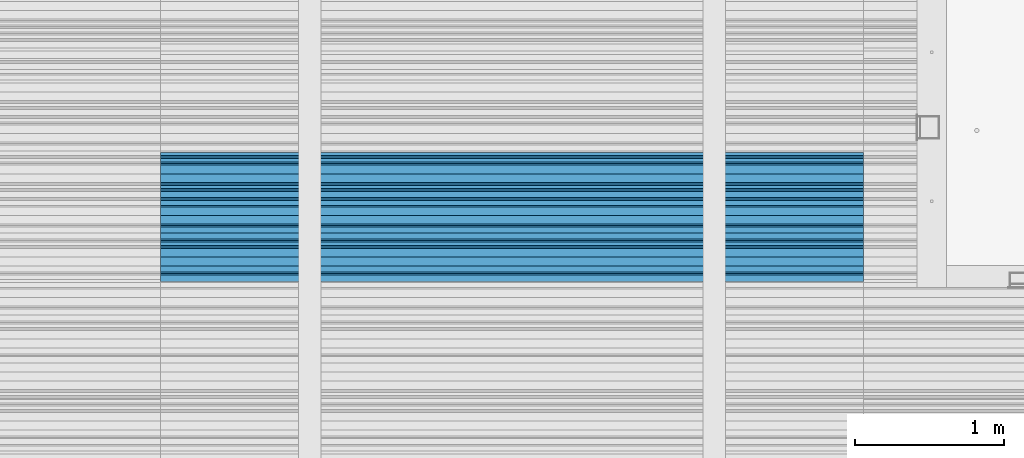
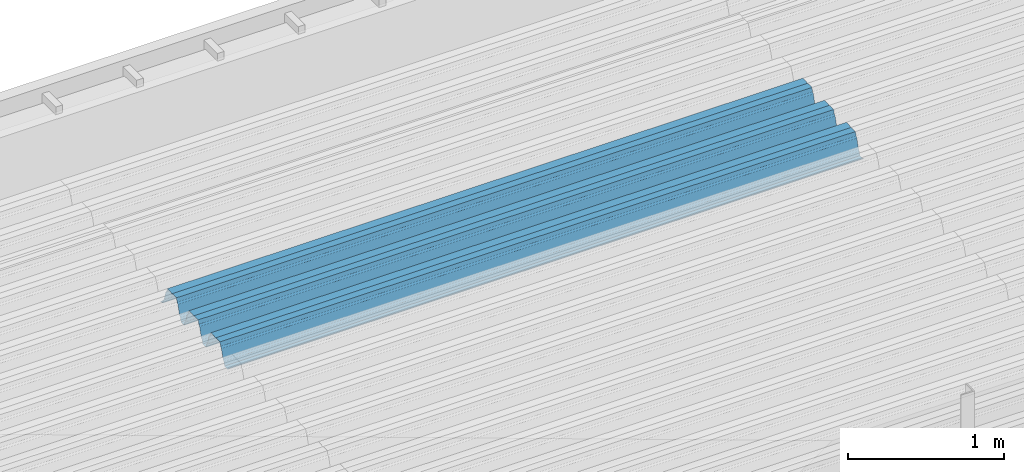
# One storey, part 33 of 153: 1 beam, 1 element without a shape of its own.
"""IFC2X3 building model written with IfcOpenShell, lengths in millimetres."""

from ifc_helpers import new_model, si_unit, frame, origin_with_axes, place, context, subcontext, project, spatial, faceted_brep, material, type_object, element, aggregate, save


model = new_model("IFC2X3")

# Units and contexts
model_context = context("Model", 3, precision=1e-05, world=origin_with_axes())
body_context = subcontext(model_context, "Body", "Model", "MODEL_VIEW")
ifc_project = project(units=[si_unit("LENGTHUNIT", "METRE", prefix="MILLI"), si_unit("AREAUNIT", "SQUARE_METRE"), si_unit("VOLUMEUNIT", "CUBIC_METRE"), si_unit("MASSUNIT", "GRAM", prefix="KILO"), si_unit("TIMEUNIT", "SECOND"), si_unit("PLANEANGLEUNIT", "RADIAN"), si_unit("SOLIDANGLEUNIT", "STERADIAN"), si_unit("THERMODYNAMICTEMPERATUREUNIT", "DEGREE_CELSIUS"), si_unit("LUMINOUSINTENSITYUNIT", "LUMEN")], contexts=[model_context])

# Site, building, storey
site_placement = place(None, origin_with_axes())
site = spatial("IfcSite", under=ifc_project, at=site_placement, CompositionType="ELEMENT")
building_placement = place(site_placement, origin_with_axes())
building = spatial("IfcBuilding", under=site, at=building_placement, CompositionType="ELEMENT")
storey_placement = place(building_placement, origin_with_axes())
storey = spatial("IfcBuildingStorey", under=building, at=storey_placement, Name="8", CompositionType="ELEMENT", Elevation=0.0)

# Assembly, beam
assembly_placement = place(storey_placement, origin_with_axes())
assembly = element("IfcElementAssembly", 1, at=assembly_placement, inside=storey, Name="Steel Assembly", AssemblyPlace="NOTDEFINED", PredefinedType="RIGID_FRAME")
ifc_material = material(Name="STEEL/S355J2")
beam_type = type_object("IfcBeamType", Name="W", PredefinedType="NOTDEFINED")
beam_placement = place(assembly_placement, frame((17251.9999999917, 18704.9497094901, 105791.39725794), z_axis=(0.0, -0.0124990270013869, 0.999921884110963), x_axis=(-1.0, 3.00000001838171e-08, 0.0)))
beam = element("IfcBeam", 2, at=beam_placement, type_object=beam_type, material=ifc_material, ObjectType="W", context=body_context, shape_type="Brep", body=[
    faceted_brep([(0.0, -412.839996337891, -77.0100021362159), (0.0, -409.160003662109, -77.0100021362014), (4717.0, -409.160003662109, -77.0100021362159), (4717.0, -412.839996337891, -77.0100021362159), (0.0, -408.070007324222, -73.4800033569045), (4717.0, -408.070007324222, -73.480003356919), (0.0, -400.339996337894, -48.0600013732619), (4717.0, -400.339996337894, -48.0600013732765), (0.0, -399.459991455082, -46.5600013732619), (4717.0, -399.459991455078, -46.5600013732765), (0.0, -390.329986572269, -36.5499992370314), (4717.0, -390.329986572266, -36.549999237046), (0.0, -389.19000244141, -34.6300010680861), (4717.0, -389.190002441403, -34.6300010681007), (0.0, -367.820007324222, 35.3400001526024), (4717.0, -367.820007324219, 35.3400001525879), (0.0, -366.989990234379, 36.8499984741502), (4717.0, -366.989990234375, 36.8499984741356), (0.0, -357.809997558597, 46.8600006103807), (4717.0, -357.809997558594, 46.8600006103661), (0.0, -356.720001220707, 48.7700004577782), (4717.0, -356.720001220703, 48.7700004577782), (0.0, -349.309997558594, 73.1500015258935), (4717.0, -349.309997558594, 73.1500015258935), (0.0, -347.850006103516, 75.2300033569481), (4717.0, -347.850006103516, 75.2300033569481), (0.0, -345.470001220707, 76.010002136245), (4717.0, -345.470001220703, 76.0100021362305), (0.0, -305.480010986332, 76.010002136245), (4717.0, -305.480010986324, 76.0100021362305), (0.0, -304.279998779301, 75.8000030517578), (4717.0, -304.279998779301, 75.8000030517724), (0.0, -291.679992675785, 71.6999969482567), (4717.0, -291.679992675785, 71.6999969482567), (0.0, -290.179992675789, 71.2300033569481), (4717.0, -290.179992675781, 71.2300033569481), (0.0, -288.720001220707, 71.6999969482567), (4717.0, -288.720001220703, 71.6999969482422), (0.0, -276.119995117191, 75.8000030517869), (4717.0, -276.119995117188, 75.8000030517724), (0.0, -274.929992675785, 76.010002136245), (4717.0, -274.929992675785, 76.010002136245), (0.0, -234.94000244141, 76.010002136245), (4717.0, -234.94000244141, 76.010002136245), (0.0, -232.550003051758, 75.2300033569627), (4717.0, -232.550003051758, 75.2300033569481), (0.0, -231.100006103519, 73.1500015258935), (4717.0, -231.100006103516, 73.1500015258789), (0.0, -223.679992675785, 48.7700004577782), (4717.0, -223.679992675781, 48.7700004577782), (0.0, -222.589996337894, 46.8600006103661), (4717.0, -222.589996337891, 46.8600006103516), (0.0, -213.410003662113, 36.8499984741502), (4717.0, -213.410003662109, 36.8499984741356), (0.0, -212.529998779301, 35.3400001526024), (4717.0, -212.529998779297, 35.3400001526024), (0.0, -191.160003662109, -34.6300010681007), (4717.0, -191.160003662109, -34.6300010681007), (0.0, -190.070007324222, -36.5499992370605), (4717.0, -190.070007324215, -36.549999237046), (0.0, -180.940002441406, -46.560001373291), (4717.0, -180.940002441406, -46.5600013732765), (0.0, -180.059997558597, -48.0600013732619), (4717.0, -180.059997558594, -48.0600013732765), (0.0, -172.330001831055, -73.480003356919), (4717.0, -172.330001831055, -73.480003356919), (0.0, -171.240005493168, -77.0100021362159), (4717.0, -171.240005493164, -77.0100021362159), (0.0, -129.330001831062, -77.0100021362014), (4717.0, -129.330001831055, -77.0100021362159), (0.0, -128.300003051761, -73.480003356919), (4717.0, -128.300003051758, -73.4800033569336), (0.0, -120.51999664307, -48.0600013732765), (4717.0, -120.519996643063, -48.0600013732765), (0.0, -119.629997253418, -46.5600013732765), (4717.0, -119.629997253418, -46.5600013732765), (0.0, -110.500000000004, -36.5499992370314), (4717.0, -110.5, -36.549999237046), (0.0, -109.419998168949, -34.6300010680861), (4717.0, -109.419998168945, -34.6300010681007), (0.0, -88.0500030517615, 35.3400001526024), (4717.0, -88.0500030517578, 35.3400001526024), (0.0, -87.160003662113, 36.8499984741356), (4717.0, -87.160003662113, 36.8499984741356), (0.0, -78.0400009155273, 46.8600006103807), (4717.0, -78.0400009155273, 46.8600006103661), (0.0, -76.8899993896557, 48.7700004577782), (4717.0, -76.8899993896521, 48.7700004577782), (0.0, -69.4800033569336, 73.1500015258935), (4717.0, -69.4800033569336, 73.1500015258935), (0.0, -68.0299987793042, 75.2300033569336), (4717.0, -68.0299987792969, 75.2300033569481), (0.0, -65.6399993896521, 76.010002136245), (4717.0, -65.6399993896484, 76.010002136245), (0.0, -25.6499996185375, 76.0100021362596), (4717.0, -25.6499996185303, 76.010002136245), (0.0, -24.5100002288891, 75.8000030517724), (4717.0, -24.5100002288818, 75.8000030517724), (0.0, -11.8500003814697, 71.6999969482567), (4717.0, -11.8500003814661, 71.6999969482567), (0.0, -10.3999996185339, 71.2300033569481), (4717.0, -10.3999996185303, 71.2300033569336), (0.0, -8.89999961853391, 71.6999969482567), (4717.0, -8.89999961853391, 71.6999969482567), (0.0, 3.71000003814333, 75.8000030517724), (4717.0, 3.71000003814697, 75.8000030517869), (0.0, 4.90000009536379, 76.0100021362596), (4717.0, 4.90000009536379, 76.010002136245), (0.0, 44.8899993896484, 76.010002136245), (4717.0, 44.8899993896484, 76.010002136245), (0.0, 47.2799987792932, 75.2300033569481), (4717.0, 47.2799987792969, 75.2300033569481), (0.0, 48.6800003051721, 73.1500015258935), (4717.0, 48.6800003051758, 73.1500015258789), (0.0, 56.1500015258753, 48.7700004577782), (4717.0, 56.1500015258789, 48.7700004577782), (0.0, 57.2400016784632, 46.8600006103807), (4717.0, 57.2400016784632, 46.8600006103661), (0.0, 66.3700027465784, 36.8499984741211), (4717.0, 66.3700027465857, 36.8499984741356), (0.0, 67.2499999999964, 35.3400001526024), (4717.0, 67.2500000000036, 35.3400001526024), (0.0, 88.6200027465748, -34.6300010681007), (4717.0, 88.620002746582, -34.6300010681152), (0.0, 89.709999084469, -36.549999237046), (4717.0, 89.7099990844727, -36.5499992370605), (0.0, 98.8899993896412, -46.5600013732765), (4717.0, 98.8899993896484, -46.5600013732765), (0.0, 99.7699966430628, -48.0600013732765), (4717.0, 99.7699966430664, -48.060001373291), (0.0, 107.499999999996, -73.4800033569336), (4717.0, 107.5, -73.480003356919), (0.0, 108.589996337887, -77.0100021362014), (4717.0, 108.589996337894, -77.0100021362159), (0.0, 112.269996643063, -77.0100021362159), (4717.0, 112.269996643066, -77.0100021362159), (0.0, 146.759994506836, -77.0100021362159), (4717.0, 146.759994506836, -77.0100021362159), (0.0, 150.440002441403, -77.0100021362159), (4717.0, 150.440002441403, -77.0100021362305), (0.0, 151.529998779297, -73.480003356919), (4717.0, 151.529998779297, -73.4800033569336), (0.0, 159.30999755859, -48.0600013732765), (4717.0, 159.309997558594, -48.0600013732765), (0.0, 160.190002441406, -46.5600013732619), (4717.0, 160.190002441406, -46.5600013732765), (0.0, 169.320007324215, -36.549999237046), (4717.0, 169.320007324222, -36.5499992370605), (0.0, 170.410003662106, -34.6300010680861), (4717.0, 170.410003662109, -34.6300010681007), (0.0, 191.779998779293, 35.3400001526024), (4717.0, 191.779998779293, 35.3400001526024), (0.0, 192.660003662109, 36.8499984741502), (4717.0, 192.660003662109, 36.8499984741356), (0.0, 201.789993286129, 46.8600006103661), (4717.0, 201.789993286133, 46.8600006103661), (0.0, 202.880004882809, 48.7700004577637), (4717.0, 202.880004882813, 48.7700004577782), (0.0, 210.350006103512, 73.150001525908), (4717.0, 210.350006103516, 73.1500015258935), (0.0, 211.800003051754, 75.2300033569481), (4717.0, 211.800003051758, 75.2300033569336), (0.0, 214.190002441406, 76.010002136245), (4717.0, 214.19000244141, 76.010002136245), (0.0, 254.179992675778, 76.010002136245), (4717.0, 254.179992675778, 76.010002136245), (0.0, 255.320007324215, 75.8000030517869), (4717.0, 255.320007324222, 75.8000030517724), (0.0, 267.980010986324, 71.6999969482713), (4717.0, 267.980010986328, 71.6999969482567), (0.0, 269.429992675778, 71.2300033569481), (4717.0, 269.429992675781, 71.2300033569481), (0.0, 270.880004882809, 71.6999969482567), (4717.0, 270.880004882813, 71.6999969482567), (0.0, 283.540008544918, 75.8000030517869), (4717.0, 283.540008544918, 75.8000030517724), (0.0, 284.679992675778, 76.010002136245), (4717.0, 284.679992675778, 76.010002136245), (0.0, 324.670013427731, 76.010002136245), (4717.0, 324.670013427738, 76.010002136245), (0.0, 327.049987792969, 75.2300033569627), (4717.0, 327.049987792969, 75.2300033569481), (0.0, 328.510009765625, 73.1500015258789), (4717.0, 328.510009765625, 73.1500015258935), (0.0, 335.980010986324, 48.7700004577782), (4717.0, 335.980010986328, 48.7700004577782), (0.0, 337.05999755859, 46.8600006103661), (4717.0, 337.059997558594, 46.8600006103516), (0.0, 346.190002441399, 36.8499984741356), (4717.0, 346.190002441406, 36.8499984741211), (0.0, 347.079986572266, 35.3400001526024), (4717.0, 347.079986572266, 35.3400001526024), (0.0, 368.450012207028, -34.6300010680861), (4717.0, 368.450012207035, -34.6300010681007), (0.0, 369.529998779293, -36.5499992370314), (4717.0, 369.529998779297, -36.549999237046), (0.0, 378.660003662106, -46.5600013732619), (4717.0, 378.660003662106, -46.5600013732765), (0.0, 379.540008544918, -48.0600013732619), (4717.0, 379.540008544922, -48.0600013732765), (0.0, 387.329986572262, -73.480003356919), (4717.0, 387.329986572266, -73.4800033569045), (0.0, 388.410003662109, -77.0100021362159), (4717.0, 388.410003662109, -77.0100021362159), (0.0, 392.100006103512, -77.0100021362159), (4717.0, 392.100006103519, -77.0100021362159), (0.0, 426.589996337887, -77.0100021362159), (4717.0, 426.589996337891, -77.0100021362159), (0.0, 430.269989013668, -77.0100021362159), (4717.0, 430.269989013672, -77.0100021362305), (0.0, 431.359985351559, -73.4800033569045), (4717.0, 431.359985351563, -73.480003356919), (0.0, 433.179992675778, -67.5699996948097), (4717.0, 433.179992675781, -67.5699996948097), (0.0, 432.220001220699, -67.2699966430373), (4717.0, 432.220001220703, -67.2699966430519), (0.0, 430.410003662106, -73.1800003051612), (4717.0, 430.410003662106, -73.1800003051758), (0.0, 429.529998779293, -76.0100021362159), (4717.0, 429.529998779293, -76.0100021362159), (0.0, 426.589996337891, -76.0100021362159), (4717.0, 426.589996337891, -76.0100021362159), (0.0, 392.100006103512, -76.0100021362159), (4717.0, 392.100006103516, -76.0100021362159), (0.0, 389.149993896481, -76.0100021362014), (4717.0, 389.149993896484, -76.0100021362159), (0.0, 388.279998779293, -73.1800003051467), (4717.0, 388.279998779301, -73.1800003051612), (0.0, 380.470001220699, -47.659999847383), (4717.0, 380.470001220703, -47.6599998473976), (0.0, 379.470001220699, -45.9599990844436), (4717.0, 379.470001220703, -45.9599990844581), (0.0, 370.350006103512, -35.9599990844581), (4717.0, 370.350006103519, -35.9599990844581), (0.0, 369.369995117184, -34.2299995422218), (4717.0, 369.369995117184, -34.2299995422218), (0.0, 347.999999999996, 35.7500000000146), (4717.0, 348.0, 35.7500000000146), (0.0, 346.999999999996, 37.4399986267235), (4717.0, 347.000000000004, 37.4399986267235), (0.0, 337.880004882809, 47.450000762954), (4717.0, 337.880004882809, 47.4500007629395), (0.0, 336.899993896481, 49.1699981689453), (4717.0, 336.899993896484, 49.1699981689599), (0.0, 329.420013427731, 73.5999984741356), (4717.0, 329.420013427734, 73.5999984741356), (0.0, 327.679992675781, 76.0699996948533), (4717.0, 327.679992675781, 76.0699996948388), (0.0, 324.829986572262, 77.010002136245), (4717.0, 324.829986572266, 77.0100021362305), (0.0, 284.589996337887, 77.010002136245), (4717.0, 284.589996337891, 77.010002136245), (0.0, 283.290008544922, 76.769996643081), (4717.0, 283.290008544922, 76.769996643081), (0.0, 270.570007324215, 72.6500015258935), (4717.0, 270.570007324219, 72.6500015258935), (0.0, 269.429992675781, 72.2799987793114), (4717.0, 269.429992675781, 72.2799987793114), (0.0, 268.279998779293, 72.650001525908), (4717.0, 268.279998779297, 72.6500015258935), (0.0, 255.570007324219, 76.769996643081), (4717.0, 255.570007324219, 76.769996643081), (0.0, 254.270004272461, 77.0100021362596), (4717.0, 254.270004272461, 77.010002136245), (0.0, 214.029998779293, 77.0100021362596), (4717.0, 214.029998779297, 77.010002136245), (0.0, 211.179992675781, 76.0699996948388), (4717.0, 211.179992675781, 76.0699996948533), (0.0, 209.440002441403, 73.5999984741356), (4717.0, 209.44000244141, 73.5999984741211), (0.0, 201.960006713864, 49.1699981689599), (4717.0, 201.960006713867, 49.1699981689453), (0.0, 200.979995727532, 47.450000762954), (4717.0, 200.979995727539, 47.4500007629395), (0.0, 191.850006103508, 37.4399986267235), (4717.0, 191.850006103516, 37.439998626709), (0.0, 190.860000610352, 35.7500000000146), (4717.0, 190.860000610352, 35.75), (0.0, 169.49000549316, -34.2299995422218), (4717.0, 169.49000549316, -34.2299995422363), (0.0, 168.509994506832, -35.9599990844581), (4717.0, 168.509994506836, -35.9599990844581), (0.0, 159.380004882805, -45.9599990844436), (4717.0, 159.380004882813, -45.9599990844581), (0.0, 158.389999389645, -47.6599998473976), (4717.0, 158.389999389645, -47.6599998474121), (0.0, 150.580001831051, -73.1800003051612), (4717.0, 150.580001831058, -73.1800003051758), (0.0, 149.710006713864, -76.0100021362159), (4717.0, 149.710006713867, -76.0100021362159), (0.0, 146.759994506836, -76.0100021362159), (4717.0, 146.759994506836, -76.0100021362159), (0.0, 112.269996643063, -76.0100021362159), (4717.0, 112.269996643063, -76.0100021362159), (0.0, 109.319999694821, -76.0100021362159), (4717.0, 109.319999694821, -76.0100021362159), (0.0, 108.449996948239, -73.1900024413917), (4717.0, 108.449996948242, -73.1900024414063), (0.0, 100.690002441406, -47.659999847383), (4717.0, 100.69000244141, -47.6599998473976), (0.0, 99.6999969482386, -45.9599990844581), (4717.0, 99.6999969482422, -45.9599990844581), (0.0, 90.5199966430664, -35.9599990844581), (4717.0, 90.5199966430664, -35.9599990844727), (0.0, 89.5400009155273, -34.2299995422218), (4717.0, 89.5400009155273, -34.2299995422218), (0.0, 68.1699981689417, 35.7500000000146), (4717.0, 68.1699981689453, 35.7500000000146), (0.0, 67.1699981689417, 37.4399986267235), (4717.0, 67.1699981689453, 37.4399986267235), (0.0, 58.0499992370569, 47.4500007629686), (4717.0, 58.0499992370605, 47.450000762954), (0.0, 57.0699996948206, 49.1699981689599), (4717.0, 57.0699996948279, 49.1699981689453), (0.0, 49.5900001525843, 73.5899963379052), (4717.0, 49.5900001525879, 73.5899963378906), (0.0, 47.9099998474085, 76.0699996948388), (4717.0, 47.9099998474121, 76.0699996948242), (0.0, 45.0499992370569, 77.010002136245), (4717.0, 45.0499992370605, 77.010002136245), (0.0, 4.82000017165774, 77.010002136245), (4717.0, 4.82000017166138, 77.010002136245), (0.0, 3.47000002860659, 76.7699966430955), (4717.0, 3.47000002860659, 76.769996643081), (0.0, -9.19999980926514, 72.6500015258935), (4717.0, -9.19999980926514, 72.6500015258789), (0.0, -10.3900003433264, 72.2799987792969), (4717.0, -10.3900003433228, 72.2799987793114), (0.0, -11.5399999618567, 72.6500015258935), (4717.0, -11.5399999618494, 72.6500015258935), (0.0, -24.2600002288855, 76.769996643081), (4717.0, -24.2600002288818, 76.769996643081), (0.0, -25.559999465946, 77.0100021362596), (4717.0, -25.5599994659424, 77.010002136245), (0.0, -65.8000030517615, 77.0100021362596), (4717.0, -65.8000030517578, 77.010002136245), (0.0, -68.6500015258862, 76.0699996948533), (4717.0, -68.6500015258825, 76.0699996948388), (0.0, -70.3899993896521, 73.5999984741356), (4717.0, -70.3899993896484, 73.5999984741211), (0.0, -77.8199996948242, 49.1800003051903), (4717.0, -77.8199996948242, 49.1800003051903), (0.0, -78.8399963378943, 47.450000762954), (4717.0, -78.8399963378906, 47.4500007629395), (0.0, -87.9700012207031, 37.4399986267235), (4717.0, -87.9700012207031, 37.4399986267235), (0.0, -88.9700012207068, 35.7500000000146), (4717.0, -88.9700012207031, 35.75), (0.0, -110.339996337894, -34.2299995422218), (4717.0, -110.339996337887, -34.2299995422218), (0.0, -111.319999694828, -35.9599990844581), (4717.0, -111.319999694824, -35.9599990844581), (0.0, -120.440002441406, -45.9599990844436), (4717.0, -120.440002441406, -45.9599990844581), (0.0, -121.44000244141, -47.6599998473976), (4717.0, -121.440002441403, -47.6599998473976), (0.0, -129.250000000004, -73.1900024413771), (4717.0, -129.25, -73.1900024413917), (0.0, -130.080001831062, -76.0100021362159), (4717.0, -130.080001831055, -76.0100021362159), (0.0, -170.5, -76.0100021362014), (4717.0, -170.5, -76.0100021362159), (0.0, -171.380004882816, -73.1900024413917), (4717.0, -171.380004882813, -73.1900024414063), (0.0, -179.139999389652, -47.6599998473976), (4717.0, -179.139999389648, -47.6599998473976), (0.0, -180.130004882816, -45.9599990844581), (4717.0, -180.130004882813, -45.9599990844581), (0.0, -189.259994506836, -35.9599990844581), (4717.0, -189.259994506832, -35.9599990844581), (0.0, -190.240005493168, -34.2299995422218), (4717.0, -190.240005493164, -34.2299995422218), (0.0, -211.610000610355, 35.7500000000146), (4717.0, -211.610000610352, 35.7500000000146), (0.0, -212.600006103519, 37.4399986267381), (4717.0, -212.600006103519, 37.4399986267235), (0.0, -221.779998779301, 47.450000762954), (4717.0, -221.779998779293, 47.4500007629395), (0.0, -222.75999450684, 49.1699981689599), (4717.0, -222.759994506836, 49.1699981689599), (0.0, -230.190002441406, 73.5999984741356), (4717.0, -230.190002441406, 73.5999984741211), (0.0, -231.919998168945, 76.0699996948388), (4717.0, -231.919998168945, 76.0699996948388), (0.0, -234.779998779301, 77.010002136245), (4717.0, -234.779998779293, 77.010002136245), (0.0, -275.010009765629, 77.010002136245), (4717.0, -275.010009765625, 77.0100021362305), (0.0, -276.359985351563, 76.769996643081), (4717.0, -276.359985351563, 76.7699966430664), (0.0, -289.029998779297, 72.6500015258789), (4717.0, -289.029998779297, 72.6500015258935), (0.0, -290.179992675785, 72.2799987793114), (4717.0, -290.179992675785, 72.2799987793114), (0.0, -291.380004882816, 72.650001525908), (4717.0, -291.380004882813, 72.6500015258935), (0.0, -304.040008544926, 76.769996643081), (4717.0, -304.040008544918, 76.769996643081), (0.0, -305.390014648441, 77.010002136245), (4717.0, -305.390014648438, 77.010002136245), (0.0, -345.63000488282, 77.0100021362596), (4717.0, -345.630004882813, 77.010002136245), (0.0, -348.480010986332, 76.0699996948388), (4717.0, -348.480010986324, 76.0699996948388), (0.0, -350.220001220707, 73.5999984741356), (4717.0, -350.220001220703, 73.5999984741211), (0.0, -357.649993896492, 49.1699981689599), (4717.0, -357.649993896484, 49.1699981689744), (0.0, -358.63000488282, 47.450000762954), (4717.0, -358.630004882813, 47.450000762954), (0.0, -367.809997558594, 37.4300003051903), (4717.0, -367.809997558594, 37.4300003051903), (0.0, -368.750000000004, 35.7299995422654), (4717.0, -368.75, 35.7299995422509), (0.0, -390.109985351566, -34.2200012207031), (4717.0, -390.109985351563, -34.2200012206886), (0.0, -391.140014648441, -35.9500007629249), (4717.0, -391.140014648438, -35.9500007629103), (0.0, -400.269989013676, -45.9599990844436), (4717.0, -400.269989013672, -45.9599990844581), (0.0, -401.269989013672, -47.6599998473976), (4717.0, -401.269989013672, -47.6599998473976), (0.0, -409.029998779297, -73.1900024413917), (4717.0, -409.029998779297, -73.1900024413917), (0.0, -409.899993896488, -76.0100021362159), (4717.0, -409.899993896481, -76.0100021362305), (0.0, -412.839996337891, -76.0100021362159), (4717.0, -412.839996337891, -76.0100021362305), (0.0, -433.179992675785, -76.0100021362159), (4717.0, -433.179992675781, -76.0100021362159), (0.0, -433.179992675785, -77.0100021362159), (4717.0, -433.179992675785, -77.0100021362305)], [[[0, 1, 2, 3]], [[1, 4, 5, 2]], [[4, 6, 7, 5]], [[6, 8, 9, 7]], [[8, 10, 11, 9]], [[10, 12, 13, 11]], [[12, 14, 15, 13]], [[14, 16, 17, 15]], [[16, 18, 19, 17]], [[18, 20, 21, 19]], [[20, 22, 23, 21]], [[22, 24, 25, 23]], [[24, 26, 27, 25]], [[26, 28, 29, 27]], [[28, 30, 31, 29]], [[30, 32, 33, 31]], [[32, 34, 35, 33]], [[34, 36, 37, 35]], [[36, 38, 39, 37]], [[38, 40, 41, 39]], [[40, 42, 43, 41]], [[42, 44, 45, 43]], [[44, 46, 47, 45]], [[46, 48, 49, 47]], [[48, 50, 51, 49]], [[50, 52, 53, 51]], [[52, 54, 55, 53]], [[54, 56, 57, 55]], [[56, 58, 59, 57]], [[58, 60, 61, 59]], [[60, 62, 63, 61]], [[62, 64, 65, 63]], [[64, 66, 67, 65]], [[66, 68, 69, 67]], [[68, 70, 71, 69]], [[70, 72, 73, 71]], [[72, 74, 75, 73]], [[74, 76, 77, 75]], [[76, 78, 79, 77]], [[78, 80, 81, 79]], [[80, 82, 83, 81]], [[82, 84, 85, 83]], [[84, 86, 87, 85]], [[86, 88, 89, 87]], [[88, 90, 91, 89]], [[90, 92, 93, 91]], [[92, 94, 95, 93]], [[94, 96, 97, 95]], [[96, 98, 99, 97]], [[98, 100, 101, 99]], [[100, 102, 103, 101]], [[102, 104, 105, 103]], [[104, 106, 107, 105]], [[106, 108, 109, 107]], [[108, 110, 111, 109]], [[110, 112, 113, 111]], [[112, 114, 115, 113]], [[114, 116, 117, 115]], [[116, 118, 119, 117]], [[118, 120, 121, 119]], [[120, 122, 123, 121]], [[122, 124, 125, 123]], [[124, 126, 127, 125]], [[126, 128, 129, 127]], [[128, 130, 131, 129]], [[130, 132, 133, 131]], [[132, 134, 135, 133]], [[134, 136, 137, 135]], [[136, 138, 139, 137]], [[138, 140, 141, 139]], [[140, 142, 143, 141]], [[142, 144, 145, 143]], [[144, 146, 147, 145]], [[146, 148, 149, 147]], [[148, 150, 151, 149]], [[150, 152, 153, 151]], [[152, 154, 155, 153]], [[154, 156, 157, 155]], [[156, 158, 159, 157]], [[158, 160, 161, 159]], [[160, 162, 163, 161]], [[162, 164, 165, 163]], [[164, 166, 167, 165]], [[166, 168, 169, 167]], [[168, 170, 171, 169]], [[170, 172, 173, 171]], [[172, 174, 175, 173]], [[174, 176, 177, 175]], [[176, 178, 179, 177]], [[178, 180, 181, 179]], [[180, 182, 183, 181]], [[182, 184, 185, 183]], [[184, 186, 187, 185]], [[186, 188, 189, 187]], [[188, 190, 191, 189]], [[190, 192, 193, 191]], [[192, 194, 195, 193]], [[194, 196, 197, 195]], [[196, 198, 199, 197]], [[198, 200, 201, 199]], [[200, 202, 203, 201]], [[202, 204, 205, 203]], [[204, 206, 207, 205]], [[206, 208, 209, 207]], [[208, 210, 211, 209]], [[210, 212, 213, 211]], [[212, 214, 215, 213]], [[214, 216, 217, 215]], [[216, 218, 219, 217]], [[218, 220, 221, 219]], [[220, 222, 223, 221]], [[222, 224, 225, 223]], [[224, 226, 227, 225]], [[226, 228, 229, 227]], [[228, 230, 231, 229]], [[230, 232, 233, 231]], [[232, 234, 235, 233]], [[234, 236, 237, 235]], [[236, 238, 239, 237]], [[238, 240, 241, 239]], [[240, 242, 243, 241]], [[242, 244, 245, 243]], [[244, 246, 247, 245]], [[246, 248, 249, 247]], [[248, 250, 251, 249]], [[250, 252, 253, 251]], [[252, 254, 255, 253]], [[254, 256, 257, 255]], [[256, 258, 259, 257]], [[258, 260, 261, 259]], [[260, 262, 263, 261]], [[262, 264, 265, 263]], [[264, 266, 267, 265]], [[266, 268, 269, 267]], [[268, 270, 271, 269]], [[270, 272, 273, 271]], [[272, 274, 275, 273]], [[274, 276, 277, 275]], [[276, 278, 279, 277]], [[278, 280, 281, 279]], [[280, 282, 283, 281]], [[282, 284, 285, 283]], [[284, 286, 287, 285]], [[286, 288, 289, 287]], [[288, 290, 291, 289]], [[290, 292, 293, 291]], [[292, 294, 295, 293]], [[294, 296, 297, 295]], [[296, 298, 299, 297]], [[298, 300, 301, 299]], [[300, 302, 303, 301]], [[302, 304, 305, 303]], [[304, 306, 307, 305]], [[306, 308, 309, 307]], [[308, 310, 311, 309]], [[310, 312, 313, 311]], [[312, 314, 315, 313]], [[314, 316, 317, 315]], [[316, 318, 319, 317]], [[318, 320, 321, 319]], [[320, 322, 323, 321]], [[322, 324, 325, 323]], [[324, 326, 327, 325]], [[326, 328, 329, 327]], [[328, 330, 331, 329]], [[330, 332, 333, 331]], [[332, 334, 335, 333]], [[334, 336, 337, 335]], [[336, 338, 339, 337]], [[338, 340, 341, 339]], [[340, 342, 343, 341]], [[342, 344, 345, 343]], [[344, 346, 347, 345]], [[346, 348, 349, 347]], [[348, 350, 351, 349]], [[350, 352, 353, 351]], [[352, 354, 355, 353]], [[354, 356, 357, 355]], [[356, 358, 359, 357]], [[358, 360, 361, 359]], [[360, 362, 363, 361]], [[362, 364, 365, 363]], [[364, 366, 367, 365]], [[366, 368, 369, 367]], [[368, 370, 371, 369]], [[370, 372, 373, 371]], [[372, 374, 375, 373]], [[374, 376, 377, 375]], [[376, 378, 379, 377]], [[378, 380, 381, 379]], [[380, 382, 383, 381]], [[382, 384, 385, 383]], [[384, 386, 387, 385]], [[386, 388, 389, 387]], [[388, 390, 391, 389]], [[390, 392, 393, 391]], [[392, 394, 395, 393]], [[394, 396, 397, 395]], [[396, 398, 399, 397]], [[398, 400, 401, 399]], [[400, 402, 403, 401]], [[402, 404, 405, 403]], [[404, 406, 407, 405]], [[406, 408, 409, 407]], [[408, 410, 411, 409]], [[410, 412, 413, 411]], [[412, 414, 415, 413]], [[414, 416, 417, 415]], [[416, 418, 419, 417]], [[418, 420, 421, 419]], [[420, 422, 423, 421]], [[422, 424, 425, 423]], [[424, 426, 427, 425]], [[426, 428, 429, 427]], [[428, 430, 431, 429]], [[430, 0, 3, 431]], [[5, 7, 9, 11, 13, 15, 17, 19, 21, 23, 25, 27, 29, 31, 33, 35, 37, 39, 41, 43, 45, 47, 49, 51, 53, 55, 57, 59, 61, 63, 65, 67, 69, 71, 73, 75, 77, 79, 81, 83, 85, 87, 89, 91, 93, 95, 97, 99, 101, 103, 105, 107, 109, 111, 113, 115, 117, 119, 121, 123, 125, 127, 129, 131, 133, 135, 137, 139, 141, 143, 145, 147, 149, 151, 153, 155, 157, 159, 161, 163, 165, 167, 169, 171, 173, 175, 177, 179, 181, 183, 185, 187, 189, 191, 193, 195, 197, 199, 201, 203, 205, 207, 209, 211, 213, 215, 217, 219, 221, 223, 225, 227, 229, 231, 233, 235, 237, 239, 241, 243, 245, 247, 249, 251, 253, 255, 257, 259, 261, 263, 265, 267, 269, 271, 273, 275, 277, 279, 281, 283, 285, 287, 289, 291, 293, 295, 297, 299, 301, 303, 305, 307, 309, 311, 313, 315, 317, 319, 321, 323, 325, 327, 329, 331, 333, 335, 337, 339, 341, 343, 345, 347, 349, 351, 353, 355, 357, 359, 361, 363, 365, 367, 369, 371, 373, 375, 377, 379, 381, 383, 385, 387, 389, 391, 393, 395, 397, 399, 401, 403, 405, 407, 409, 411, 413, 415, 417, 419, 421, 423, 425, 427, 429, 431, 3, 2]], [[430, 428, 426, 424, 422, 420, 418, 416, 414, 412, 410, 408, 406, 404, 402, 400, 398, 396, 394, 392, 390, 388, 386, 384, 382, 380, 378, 376, 374, 372, 370, 368, 366, 364, 362, 360, 358, 356, 354, 352, 350, 348, 346, 344, 342, 340, 338, 336, 334, 332, 330, 328, 326, 324, 322, 320, 318, 316, 314, 312, 310, 308, 306, 304, 302, 300, 298, 296, 294, 292, 290, 288, 286, 284, 282, 280, 278, 276, 274, 272, 270, 268, 266, 264, 262, 260, 258, 256, 254, 252, 250, 248, 246, 244, 242, 240, 238, 236, 234, 232, 230, 228, 226, 224, 222, 220, 218, 216, 214, 212, 210, 208, 206, 204, 202, 200, 198, 196, 194, 192, 190, 188, 186, 184, 182, 180, 178, 176, 174, 172, 170, 168, 166, 164, 162, 160, 158, 156, 154, 152, 150, 148, 146, 144, 142, 140, 138, 136, 134, 132, 130, 128, 126, 124, 122, 120, 118, 116, 114, 112, 110, 108, 106, 104, 102, 100, 98, 96, 94, 92, 90, 88, 86, 84, 82, 80, 78, 76, 74, 72, 70, 68, 66, 64, 62, 60, 58, 56, 54, 52, 50, 48, 46, 44, 42, 40, 38, 36, 34, 32, 30, 28, 26, 24, 22, 20, 18, 16, 14, 12, 10, 8, 6, 4, 1, 0]]]),
])
aggregate(assembly, [beam])

save(model, "model.ifc")
